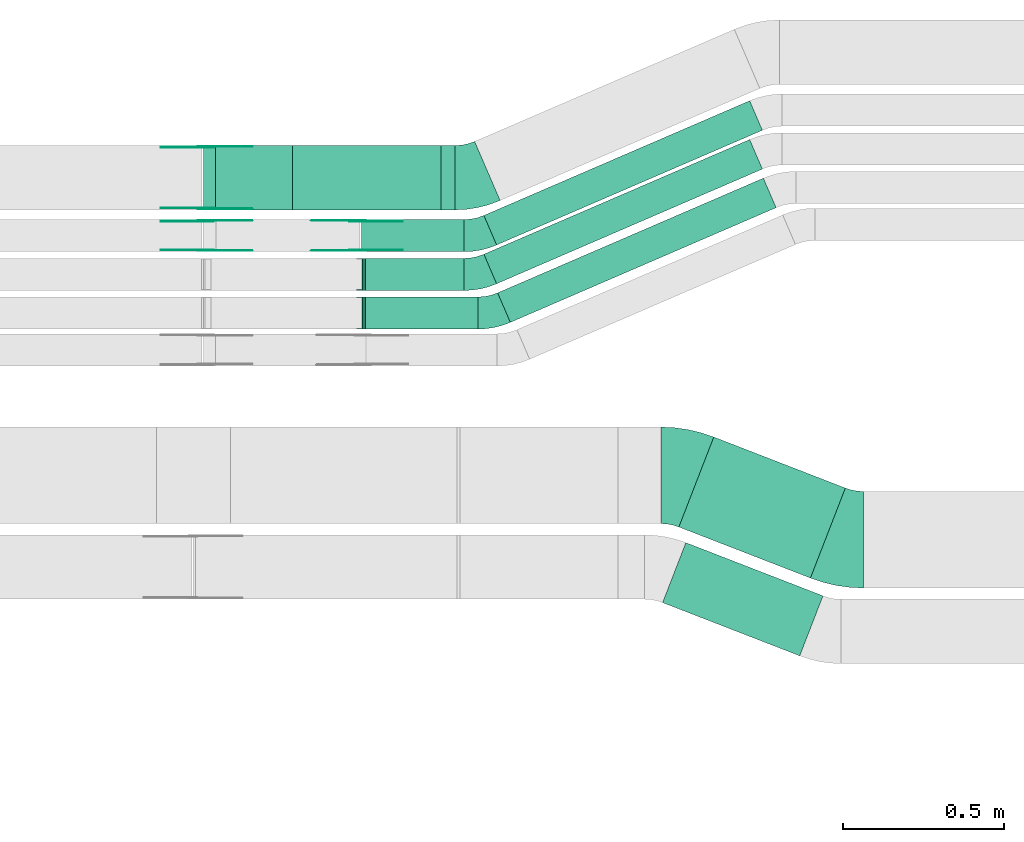
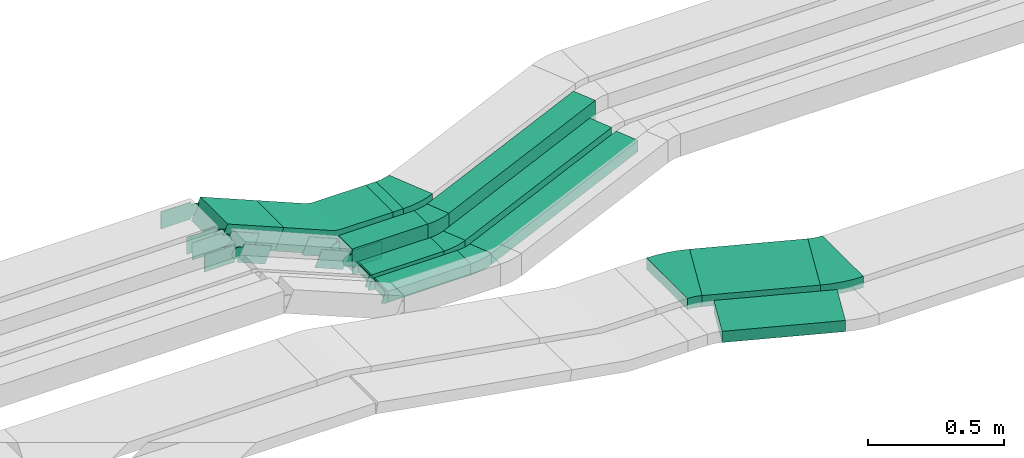
# One storey, part 17 of 31: 21 flow fittings, 10 flow segments.
"""IFC2X3 building model written with IfcOpenShell, lengths in millimetres."""

from ifc_helpers import new_model, entity, si_unit, converted_unit, derived_unit, direction, frame, frame_2d, origin, origin_2d_with_axis, place, context, subcontext, project, spatial, polyline, circle_curve, parameter, trimmed, segment, composite_curve, rectangle, outline, extrude, faceted_brep, source, transform, mapped, material, type_object, type_shapes, element, save


model = new_model("IFC2X3")

# Units and contexts
model_context = context("Model", 3, precision=0.01, world=origin(), true_north=direction((6.12303176911189e-17, 1.0)))
body_context = subcontext(model_context, "Body", "Model", "MODEL_VIEW")
ifc_project = project(units=[si_unit("LENGTHUNIT", "METRE", prefix="MILLI"), si_unit("AREAUNIT", "SQUARE_METRE"), si_unit("VOLUMEUNIT", "CUBIC_METRE"), converted_unit("PLANEANGLEUNIT", "DEGREE", entity("IfcRatioMeasure", 0.0174532925199433), si_unit("PLANEANGLEUNIT", "RADIAN"), dimensions=[0, 0, 0, 0, 0, 0, 0]), si_unit("MASSUNIT", "GRAM", prefix="KILO"), derived_unit("MASSDENSITYUNIT", [(si_unit("MASSUNIT", "GRAM", prefix="KILO"), 1), (si_unit("LENGTHUNIT", "METRE"), -3)]), derived_unit("MOMENTOFINERTIAUNIT", [(si_unit("LENGTHUNIT", "METRE"), 4)]), si_unit("TIMEUNIT", "SECOND"), si_unit("FREQUENCYUNIT", "HERTZ"), si_unit("THERMODYNAMICTEMPERATUREUNIT", "DEGREE_CELSIUS"), derived_unit("THERMALTRANSMITTANCEUNIT", [(si_unit("MASSUNIT", "GRAM", prefix="KILO"), 1), (si_unit("THERMODYNAMICTEMPERATUREUNIT", "KELVIN"), -1), (si_unit("TIMEUNIT", "SECOND"), -3)]), derived_unit("VOLUMETRICFLOWRATEUNIT", [(si_unit("LENGTHUNIT", "METRE"), 3), (si_unit("TIMEUNIT", "SECOND"), -1)]), derived_unit("MASSFLOWRATEUNIT", [(si_unit("MASSUNIT", "GRAM", prefix="KILO"), 1), (si_unit("TIMEUNIT", "SECOND"), -1)]), derived_unit("ROTATIONALFREQUENCYUNIT", [(si_unit("TIMEUNIT", "SECOND"), -1)]), si_unit("ELECTRICCURRENTUNIT", "AMPERE"), si_unit("ELECTRICVOLTAGEUNIT", "VOLT"), si_unit("POWERUNIT", "WATT"), si_unit("FORCEUNIT", "NEWTON", prefix="KILO"), si_unit("ILLUMINANCEUNIT", "LUX"), si_unit("LUMINOUSFLUXUNIT", "LUMEN"), si_unit("LUMINOUSINTENSITYUNIT", "CANDELA"), derived_unit("USERDEFINED", [(si_unit("MASSUNIT", "GRAM", prefix="KILO"), -1), (si_unit("LENGTHUNIT", "METRE"), -2), (si_unit("TIMEUNIT", "SECOND"), 3), (si_unit("LUMINOUSFLUXUNIT", "LUMEN"), 1)]), derived_unit("LINEARVELOCITYUNIT", [(si_unit("LENGTHUNIT", "METRE"), 1), (si_unit("TIMEUNIT", "SECOND"), -1)]), si_unit("PRESSUREUNIT", "PASCAL"), derived_unit("USERDEFINED", [(si_unit("LENGTHUNIT", "METRE"), -2), (si_unit("MASSUNIT", "GRAM", prefix="KILO"), 1), (si_unit("TIMEUNIT", "SECOND"), -2)]), derived_unit("LINEARFORCEUNIT", [(si_unit("MASSUNIT", "GRAM", prefix="KILO"), 1), (si_unit("LENGTHUNIT", "METRE"), 1), (si_unit("TIMEUNIT", "SECOND"), -2), (si_unit("LENGTHUNIT", "METRE"), -1)]), derived_unit("PLANARFORCEUNIT", [(si_unit("MASSUNIT", "GRAM", prefix="KILO"), 1), (si_unit("LENGTHUNIT", "METRE"), 1), (si_unit("TIMEUNIT", "SECOND"), -2), (si_unit("LENGTHUNIT", "METRE"), -2)])], contexts=[model_context])

# Site, building, storey
site_placement = place(None, frame((0.0, -0.00077364408347762, 0.0)))
site = spatial("IfcSite", under=ifc_project, at=site_placement, CompositionType="ELEMENT")
building_placement = place(site_placement, origin())
building = spatial("IfcBuilding", under=site, at=building_placement, CompositionType="ELEMENT")
storey_placement = place(building_placement, frame((0.0, 0.0, 15900.0)))
storey = spatial("IfcBuildingStorey", under=building, at=storey_placement, CompositionType="ELEMENT", Elevation=15900.0)

# Flow segments
cable_carrier_segment_type = type_object("IfcCableCarrierSegmentType", PredefinedType="CABLETRAYSEGMENT")
flow_segment_1_placement = place(storey_placement, frame((45925.0, 15609.9939089947, 2635.0)))
element("IfcFlowSegment", 1, at=flow_segment_1_placement, inside=storey, type_object=cable_carrier_segment_type, context=body_context, shape_type="SweptSolid", body=[
    extrude(rectangle(XDim=43.6419436420277, YDim=199.999999999998, at=frame_2d((-4.33075797445781e-12, 0.0), x_axis=(1.0, 0.0))), frame((21.8209718210095, 100.0, 0.0), z_axis=(0.0, 0.0, 1.0), x_axis=(-1.0, 0.0, 0.0)), (0.0, 0.0, 1.0), 99.9999999999989),
])
flow_segment_2_placement = place(storey_placement, frame((45677.8502731352, 15479.9939089947, 2635.0)))
element("IfcFlowSegment", 2, at=flow_segment_2_placement, inside=storey, type_object=cable_carrier_segment_type, context=body_context, shape_type="SweptSolid", body=[
    extrude(rectangle(XDim=319.463320328954, YDim=99.9999999999989, at=frame_2d((4.32009983342141e-12, 2.16715534406831e-12), x_axis=(1.0, 0.0))), frame((159.731660164481, 50.0, 0.0), z_axis=(0.0, 0.0, 1.0), x_axis=(-1.0, 0.0, 0.0)), (0.0, 0.0, 1.0), 100.000000000001),
])
flow_segment_3_placement = place(storey_placement, frame((45690.6793381393, 15359.4580000518, 2637.2447203761)))
element("IfcFlowSegment", 3, at=flow_segment_3_placement, inside=storey, type_object=cable_carrier_segment_type, context=body_context, shape_type="SweptSolid", body=[
    extrude(rectangle(XDim=306.634255324862, YDim=99.9999999999989, at=frame_2d((0.0, -1.08357767203415e-12), x_axis=(1.0, 0.0))), frame((153.317127662431, 50.0, 0.0), z_axis=(0.0, 0.0, 1.0), x_axis=(-1.0, 0.0, 0.0)), (0.0, 0.0, 1.0), 50.0000000000016),
])
flow_segment_4_placement = place(storey_placement, frame((45690.6793381402, 15239.4580000517, 2637.24472037608)))
element("IfcFlowSegment", 4, at=flow_segment_4_placement, inside=storey, type_object=cable_carrier_segment_type, context=body_context, shape_type="SweptSolid", body=[
    extrude(rectangle(XDim=349.299577232627, YDim=99.9999999999989, at=frame_2d((0.0, 1.08357767203415e-12), x_axis=(1.0, 0.0))), frame((174.649788616314, 50.0, 0.0)), (0.0, 0.0, 1.0), 50.0000000000016),
])
flow_segment_5_placement = place(storey_placement, frame((45186.6615770121, 15609.9939089947, 2735.0)))
element("IfcFlowSegment", 5, at=flow_segment_5_placement, inside=storey, type_object=cable_carrier_segment_type, context=body_context, shape_type="SweptSolid", body=[
    extrude(rectangle(XDim=99.9999999999999, YDim=199.999999999998, at=frame_2d((-2.00373051484348e-12, 0.0), x_axis=(1.0, 0.0))), frame((19.2307692307835, 100.0, 145.461538461525), z_axis=(0.923076923076912, 0.0, -0.384615384615411), x_axis=(0.384615384615411, 0.0, 0.923076923076912)), (0.0, 0.0, 1.0), 258.199999999951),
])
flow_segment_6_placement = place(storey_placement, frame((46664.5749166185, 14465.8684098194, 2650.0)))
element("IfcFlowSegment", 6, at=flow_segment_6_placement, inside=storey, type_object=cable_carrier_segment_type, context=body_context, shape_type="SweptSolid", body=[
    extrude(rectangle(XDim=438.486664288002, YDim=299.999999999994, at=frame_2d((3.63797880709171e-12, 2.57216470345156e-12), x_axis=(1.0, 0.0))), frame((258.65944354028, 219.157098694449, 0.0), z_axis=(0.0, 0.0, 1.0), x_axis=(-0.932264171028324, 0.361778268303765, 0.0)), (0.0, 0.0, 1.0), 50.0000000000016),
])
flow_segment_7_placement = place(storey_placement, frame((46613.9364281998, 14224.0948269223, 2650.0)))
element("IfcFlowSegment", 7, at=flow_segment_7_placement, inside=storey, type_object=cable_carrier_segment_type, context=body_context, shape_type="SweptSolid", body=[
    extrude(rectangle(XDim=457.209687450545, YDim=200.000000000007, at=frame_2d((4.03588273911737e-12, 1.57029944602982e-12), x_axis=(1.0, 0.0))), frame((249.297931958977, 175.930681591621, 0.0), z_axis=(0.0, 0.0, 1.0), x_axis=(0.932264171028315, -0.361778268303789, 0.0)), (0.0, 0.0, 1.0), 50.0000000000016),
])
flow_segment_8_placement = place(storey_placement, frame((46058.6720048741, 15500.8565107629, 2635.0)))
element("IfcFlowSegment", 8, at=flow_segment_8_placement, inside=storey, type_object=cable_carrier_segment_type, context=body_context, shape_type="SweptSolid", body=[
    extrude(rectangle(XDim=899.544928031288, YDim=100.000000000003, at=origin_2d_with_axis()), frame((432.765117043848, 224.137398231788, 0.0), z_axis=(0.0, 0.0, 1.0), x_axis=(-0.918134666973487, -0.396268511619942, 0.0)), (0.0, 0.0, 1.0), 99.9999999999989),
])
flow_segment_9_placement = place(storey_placement, frame((46058.6720048741, 15380.32060182, 2637.24472037611)))
element("IfcFlowSegment", 9, at=flow_segment_9_placement, inside=storey, type_object=cable_carrier_segment_type, context=body_context, shape_type="SweptSolid", body=[
    extrude(rectangle(XDim=899.544928031294, YDim=99.999999999988, at=frame_2d((4.54747350886464e-13, 9.80548975348938e-13), x_axis=(1.0, 0.0))), frame((432.765117043848, 224.13739823177, 0.0), z_axis=(0.0, 0.0, 1.0), x_axis=(-0.9181346669735, -0.396268511619913, 0.0)), (0.0, 0.0, 1.0), 50.0000000000016),
])
flow_segment_10_placement = place(storey_placement, frame((46101.3373267828, 15260.32060182, 2637.24472037609)))
element("IfcFlowSegment", 10, at=flow_segment_10_placement, inside=storey, type_object=cable_carrier_segment_type, context=body_context, shape_type="SweptSolid", body=[
    extrude(rectangle(XDim=899.544928031396, YDim=99.999999999988, at=frame_2d((-6.70752342557535e-12, 6.43041175862891e-12), x_axis=(1.0, 0.0))), frame((432.7651170439, 224.137398231796, 0.0), z_axis=(0.0, 0.0, 1.0), x_axis=(-0.918134666973501, -0.396268511619909, 0.0)), (0.0, 0.0, 1.0), 50.0000000000016),
])

# Flow fittings
ifc_material_1 = material(Name="G")
cable_carrier_fitting_type_1 = type_object("IfcCableCarrierFittingType", PredefinedType="NOTDEFINED", material=ifc_material_1)
shared_shape_1 = source(origin(), body_context, "Body", "SweptSolid", [
    extrude(outline(composite_curve([segment(trimmed(circle_curve(frame_2d((-41.4651162790697, 0.0), x_axis=(1.0, 0.0)), 25.0), [parameter(90.0000000000007)], [parameter(270.0)], True, "PARAMETER"), True, "CONTINUOUS"), segment(polyline([(-41.4651162790697, -25.0), (-29.9651162790697, -25.0)]), True, "CONTINUOUS"), segment(polyline([(-29.9651162790697, -25.0), (-28.1046511627907, -38.5)]), True, "CONTINUOUS"), segment(polyline([(-28.1046511627907, -38.5), (99.5348837209303, -38.5)]), True, "CONTINUOUS"), segment(polyline([(99.5348837209303, -38.5), (99.5348837209303, 38.5)]), True, "CONTINUOUS"), segment(polyline([(99.5348837209303, 38.5), (-28.1046511627907, 38.5)]), True, "CONTINUOUS"), segment(polyline([(-28.1046511627907, 38.5), (-29.9651162790697, 25.0)]), True, "CONTINUOUS"), segment(polyline([(-29.9651162790697, 25.0), (-41.46511627907, 25.0)]), True, "CONTINUOUS")], self_intersect=False)), frame((41.4651162790697, 0.0, 0.0), z_axis=(0.0, 0.0, -1.0), x_axis=(1.0, 0.0, 0.0)), (0.0, 0.0, -1.0), 2.0),
])
type_shapes(cable_carrier_fitting_type_1, [shared_shape_1])
for number, where, z_axis, x_axis in (
    (11, (45195.0, 15575.4539090049, 2885.0), (0.0, 1.0, 0.0), (0.920411299750602, 0.0, -0.390951453880668)),
    (12, (45665.8571184332, 15575.4539090049, 2685.0), (0.0, 1.0, 0.0), (-0.920411299750602, 0.0, 0.390951453880668)),
    (13, (45195.0, 15805.4539090048, 2885.0), (0.0, 1.0, 0.0), (0.92307692307691, 0.0, -0.384615384615415)),
):
    element("IfcFlowFitting", number, at=place(storey_placement, frame(where, z_axis=z_axis, x_axis=x_axis)), inside=storey, type_object=cable_carrier_fitting_type_1, material=ifc_material_1, context=body_context, shape_type="MappedRepresentation", body=[
        mapped(shared_shape_1, transform((0.0, 0.0, 0.0), scale=1.0)),
    ])
cable_carrier_fitting_type_2 = type_object("IfcCableCarrierFittingType", PredefinedType="NOTDEFINED", material=ifc_material_1)
shared_shape_2 = source(origin(), body_context, "Body", "SweptSolid", [
    extrude(outline(composite_curve([segment(trimmed(circle_curve(frame_2d((-41.4651162790697, 0.0), x_axis=(1.0, 0.0)), 25.0), [parameter(90.0000000000007)], [parameter(270.0)], True, "PARAMETER"), True, "CONTINUOUS"), segment(polyline([(-41.4651162790697, -25.0), (-29.9651162790697, -25.0)]), True, "CONTINUOUS"), segment(polyline([(-29.9651162790697, -25.0), (-28.1046511627907, -38.5)]), True, "CONTINUOUS"), segment(polyline([(-28.1046511627907, -38.5), (99.5348837209303, -38.5)]), True, "CONTINUOUS"), segment(polyline([(99.5348837209303, -38.5), (99.5348837209303, 38.5)]), True, "CONTINUOUS"), segment(polyline([(99.5348837209303, 38.5), (-28.1046511627907, 38.5)]), True, "CONTINUOUS"), segment(polyline([(-28.1046511627907, 38.5), (-29.9651162790697, 25.0)]), True, "CONTINUOUS"), segment(polyline([(-29.9651162790697, 25.0), (-41.46511627907, 25.0)]), True, "CONTINUOUS")], self_intersect=False)), frame((41.4651162790697, 0.0, 0.0)), (0.0, 0.0, 1.0), 2.0),
])
type_shapes(cable_carrier_fitting_type_2, [shared_shape_2])
for number, where, z_axis, x_axis in (
    (14, (45195.0, 15484.5339089845, 2885.0), (0.0, -1.0, 0.0), (0.920411299750602, 0.0, -0.390951453880668)),
    (15, (45665.8571184332, 15484.5339089845, 2685.0), (0.0, -1.0, 0.0), (-0.920411299750602, 0.0, 0.390951453880668)),
    (16, (45195.0, 15614.5339089845, 2885.0), (0.0, -1.0, 0.0), (0.92307692307691, 0.0, -0.384615384615415)),
):
    element("IfcFlowFitting", number, at=place(storey_placement, frame(where, z_axis=z_axis, x_axis=x_axis)), inside=storey, type_object=cable_carrier_fitting_type_2, material=ifc_material_1, context=body_context, shape_type="MappedRepresentation", body=[
        mapped(shared_shape_2, transform((0.0, 0.0, 0.0), scale=1.0)),
    ])
cable_carrier_fitting_type_3 = type_object("IfcCableCarrierFittingType", PredefinedType="NOTDEFINED", material=ifc_material_1)
shared_shape_3 = source(origin(), body_context, "Body", "SweptSolid", [
    extrude(outline(composite_curve([segment(trimmed(circle_curve(frame_2d((-41.4651162790697, 0.0), x_axis=(1.0, 0.0)), 25.0), [parameter(90.0000000000007)], [parameter(270.0)], True, "PARAMETER"), True, "CONTINUOUS"), segment(polyline([(-41.4651162790697, -25.0), (-29.9651162790697, -25.0)]), True, "CONTINUOUS"), segment(polyline([(-29.9651162790697, -25.0), (-28.1046511627907, -38.5)]), True, "CONTINUOUS"), segment(polyline([(-28.1046511627907, -38.5), (99.5348837209303, -38.5)]), True, "CONTINUOUS"), segment(polyline([(99.5348837209303, -38.5), (99.5348837209303, 38.5)]), True, "CONTINUOUS"), segment(polyline([(99.5348837209303, 38.5), (-28.1046511627907, 38.5)]), True, "CONTINUOUS"), segment(polyline([(-28.1046511627907, 38.5), (-29.9651162790697, 25.0)]), True, "CONTINUOUS"), segment(polyline([(-29.9651162790697, 25.0), (-41.46511627907, 25.0)]), True, "CONTINUOUS")], self_intersect=False)), frame((41.4651162790697, 0.0, 0.0), z_axis=(0.0, 0.0, -1.0), x_axis=(1.0, 0.0, 0.0)), (0.0, 0.0, -1.0), 2.0),
])
type_shapes(cable_carrier_fitting_type_3, [shared_shape_3])
for number, where, z_axis, x_axis in (
    (17, (45195.0, 15486.5339089845, 2885.0), (0.0, -1.0, 0.0), (-1.0, 0.0, 0.0)),
    (18, (45665.8571184332, 15486.5339089845, 2685.0), (0.0, -1.0, 0.0), (1.0, 0.0, 0.0)),
    (19, (45195.0, 15616.5339089845, 2885.0), (0.0, -1.0, 0.0), (-1.0, 0.0, 0.0)),
):
    element("IfcFlowFitting", number, at=place(storey_placement, frame(where, z_axis=z_axis, x_axis=x_axis)), inside=storey, type_object=cable_carrier_fitting_type_3, material=ifc_material_1, context=body_context, shape_type="MappedRepresentation", body=[
        mapped(shared_shape_3, transform((0.0, 0.0, 0.0), scale=1.0)),
    ])
cable_carrier_fitting_type_4 = type_object("IfcCableCarrierFittingType", PredefinedType="NOTDEFINED", material=ifc_material_1)
shared_shape_4 = source(origin(), body_context, "Body", "SweptSolid", [
    extrude(outline(composite_curve([segment(trimmed(circle_curve(frame_2d((-41.4651162790697, 0.0), x_axis=(1.0, 0.0)), 25.0), [parameter(90.0000000000007)], [parameter(270.0)], True, "PARAMETER"), True, "CONTINUOUS"), segment(polyline([(-41.4651162790697, -25.0), (-29.9651162790697, -25.0)]), True, "CONTINUOUS"), segment(polyline([(-29.9651162790697, -25.0), (-28.1046511627907, -38.5)]), True, "CONTINUOUS"), segment(polyline([(-28.1046511627907, -38.5), (99.5348837209303, -38.5)]), True, "CONTINUOUS"), segment(polyline([(99.5348837209303, -38.5), (99.5348837209303, 38.5)]), True, "CONTINUOUS"), segment(polyline([(99.5348837209303, 38.5), (-28.1046511627907, 38.5)]), True, "CONTINUOUS"), segment(polyline([(-28.1046511627907, 38.5), (-29.9651162790697, 25.0)]), True, "CONTINUOUS"), segment(polyline([(-29.9651162790697, 25.0), (-41.46511627907, 25.0)]), True, "CONTINUOUS")], self_intersect=False)), frame((41.4651162790697, 0.0, 0.0)), (0.0, 0.0, 1.0), 2.0),
])
type_shapes(cable_carrier_fitting_type_4, [shared_shape_4])
for number, where, z_axis, x_axis in (
    (20, (45195.0, 15573.4539090049, 2885.0), (0.0, 1.0, 0.0), (-1.0, 0.0, 0.0)),
    (21, (45665.8571184332, 15573.4539090049, 2685.0), (0.0, 1.0, 0.0), (1.0, 0.0, 0.0)),
    (22, (45195.0, 15803.4539090048, 2885.0), (0.0, 1.0, 0.0), (-1.0, 0.0, 0.0)),
):
    element("IfcFlowFitting", number, at=place(storey_placement, frame(where, z_axis=z_axis, x_axis=x_axis)), inside=storey, type_object=cable_carrier_fitting_type_4, material=ifc_material_1, context=body_context, shape_type="MappedRepresentation", body=[
        mapped(shared_shape_4, transform((0.0, 0.0, 0.0), scale=1.0)),
    ])
ifc_material_2 = material()
cable_carrier_fitting_type_5 = type_object("IfcCableCarrierFittingType", PredefinedType="NOTDEFINED", material=ifc_material_2)
shared_shape_5 = source(origin(), body_context, "Body", "Brep", [
    faceted_brep([(-9.86154249456779, 25.0, 50.0), (-9.86154249456779, 25.0, -50.0), (-9.86154249456795, -25.0, -50.0), (-9.86154249456795, -25.0, -47.4600000101565), (-9.8615424945678, 22.46000001016, -47.4600000101565), (-9.8615424945678, 22.46000001016, 47.4600000101635), (-9.86154249456795, -25.0, 47.4600000101635), (-9.86154249456795, -25.0, 50.0), (-0.369250245826843, 26.8721728676359, 50.0), (18.6153342516549, -19.3834813970913, 50.0), (18.6153342516549, -19.3834813970913, 47.4600000101635), (0.595166642787549, 24.522385640387, 47.4600000101635), (0.595166642787553, 24.522385640387, -47.4600000101565), (18.6153342516549, -19.3834813970913, -47.4600000101565), (18.6153342516549, -19.3834813970913, -50.0), (-0.369250245826849, 26.8721728676359, -50.0), (-4.93077124728357, 25.0, 50.0), (-4.93077124728367, 25.0, -50.0), (4.93077124728457, -25.0, -50.0), (4.93077124728457, -25.0, -47.4600000101565), (-4.42980489056346, 22.46000001016, -47.4600000101565), (-4.42980489056346, 22.46000001016, 47.4600000101635), (4.93077124728457, -25.0, 47.4600000101635), (4.93077124728457, -25.0, 50.0)], [[[0, 1, 2, 3, 4, 5, 6, 7]], [[8, 9, 10, 11, 12, 13, 14, 15]], [[1, 0, 16, 17]], [[2, 1, 17, 15, 14, 18]], [[3, 2, 18, 19]], [[4, 3, 19, 13, 12, 20]], [[5, 4, 20, 21]], [[6, 5, 21, 11, 10, 22]], [[7, 6, 22, 23]], [[0, 7, 23, 9, 8, 16]], [[17, 16, 8, 15]], [[19, 18, 14, 13]], [[21, 20, 12, 11]], [[23, 22, 10, 9]]]),
])
type_shapes(cable_carrier_fitting_type_5, [shared_shape_5])
for number, where, z_axis, x_axis in (
    (23, (45680.8177956447, 15409.4580000518, 2662.24472037612), (0.0, 1.0, 0.0), (-1.0, 0.0, 0.0)),
    (24, (45680.8177956456, 15289.4580000518, 2662.24472037611), (0.0, -1.0, 0.0), (0.925113085294543, 0.0, -0.379691689949639)),
):
    element("IfcFlowFitting", number, at=place(storey_placement, frame(where, z_axis=z_axis, x_axis=x_axis)), inside=storey, type_object=cable_carrier_fitting_type_5, material=ifc_material_2, context=body_context, shape_type="MappedRepresentation", body=[
        mapped(shared_shape_5, transform((0.0, 0.0, 0.0), scale=1.0)),
    ])
cable_carrier_fitting_type_6 = type_object("IfcCableCarrierFittingType", Name="470_DKC_S5_CS 90 internal vertical angle:-", PredefinedType="NOTDEFINED", material=ifc_material_2)
shared_shape_6 = source(origin(), body_context, "Body", "SweptSolid", [
    extrude(outline(composite_curve([segment(polyline([(-244.557692307692, -77.2115384615417), (-27.5576923076944, -77.2115384615417)]), True, "CONTINUOUS"), segment(trimmed(circle_curve(frame_2d((-27.5576923076947, 137.788461538457), x_axis=(0.0, -1.0)), 214.999999999999), [parameter(0.0)], [parameter(22.6198649480428)], True, "PARAMETER"), True, "CONTINUOUS"), segment(polyline([(55.134615384621, -60.6730769230767), (255.442307692308, 22.788461538469)]), True, "CONTINUOUS"), segment(polyline([(255.442307692308, 22.7884615384689), (216.980769230765, 115.09615384616)]), True, "CONTINUOUS"), segment(polyline([(216.980769230765, 115.09615384616), (16.6730769230785, 31.6346153846142)]), True, "CONTINUOUS"), segment(trimmed(circle_curve(frame_2d((-27.5576923076947, 137.788461538457), x_axis=(0.0, -1.0)), 114.999999999999), [parameter(0.0)], [parameter(22.6198649480428)], True, "PARAMETER"), False, "CONTINUOUS"), segment(polyline([(-27.5576923076944, 22.7884615384585), (-244.557692307692, 22.7884615384586)]), True, "CONTINUOUS"), segment(polyline([(-244.557692307692, 22.7884615384586), (-244.557692307692, -77.2115384615417)]), True, "CONTINUOUS")], self_intersect=False)), frame((-5.44230769230004, 27.2115384615344, -100.0)), (0.0, 0.0, 1.0), 200.0),
])
type_shapes(cable_carrier_fitting_type_6, [shared_shape_6])
flow_fitting_1_placement = place(storey_placement, frame((45675.0, 15709.9939089947, 2685.0), z_axis=(0.0, 1.0, 0.0), x_axis=(-1.0, 0.0, 0.0)))
element("IfcFlowFitting", 25, at=flow_fitting_1_placement, inside=storey, type_object=cable_carrier_fitting_type_6, material=ifc_material_2, Name="470_DKC_S5_CS 90 internal vertical angle:-", ObjectType="470_DKC_S5_CS 90 internal vertical angle:-", context=body_context, shape_type="MappedRepresentation", body=[
    mapped(shared_shape_6, transform((0.0, 0.0, 0.0), scale=1.0)),
])
cable_carrier_fitting_type_7 = type_object("IfcCableCarrierFittingType", Name="470_DKC_S5_Variable Angle Elbow 0-45:-", PredefinedType="NOTDEFINED", material=ifc_material_2)
shared_shape_7 = source(origin(), body_context, "Body", "SweptSolid", [
    extrude(outline(composite_curve([segment(polyline([(-55.2498062883172, -160.250818912827), (-54.2498062883156, -160.250818912827)]), True, "CONTINUOUS"), segment(trimmed(circle_curve(frame_2d((-54.249806288324, 289.749181087173), x_axis=(0.0, -1.0)), 450.0), [parameter(0.0)], [parameter(21.2094457966376)], True, "PARAMETER"), True, "CONTINUOUS"), segment(polyline([(108.550414448369, -129.769695875574), (109.482678619397, -129.40791760727)]), True, "CONTINUOUS"), segment(polyline([(109.482678619397, -129.40791760727), (0.949198128268728, 150.271333701228)]), True, "CONTINUOUS"), segment(polyline([(0.94919812826872, 150.271333701228), (0.0169339572402172, 149.909555432924)]), True, "CONTINUOUS"), segment(trimmed(circle_curve(frame_2d((-54.249806288324, 289.749181087173), x_axis=(0.0, -1.0)), 150.0), [parameter(0.0)], [parameter(21.2094457966376)], True, "PARAMETER"), False, "CONTINUOUS"), segment(polyline([(-54.2498062883207, 139.749181087173), (-55.2498062883223, 139.749181087173)]), True, "CONTINUOUS"), segment(polyline([(-55.2498062883223, 139.749181087173), (-55.2498062883172, -160.250818912827)]), True, "CONTINUOUS")], self_intersect=False)), frame((-1.91926319939191, 10.2508189128181, -25.0)), (0.0, 0.0, 1.0), 49.9999999999992),
])
type_shapes(cable_carrier_fitting_type_7, [shared_shape_7])
for number, where, z_axis, x_axis, name in (
    (26, (47180.9237386279, 14585.0255085139, 2675.0), (0.0, 0.0, 1.0), (0.932264171028328, -0.361778268303755, 0.0), "470_DKC_S5_Variable Angle Elbow 0-45:-"),
    (27, (46665.5449816896, 14785.0255085139, 2675.0), (0.0, 0.0, 1.0), (-0.932264171028324, 0.361778268303765, 0.0), "470_DKC_S5_Variable Angle Elbow 0-45:-"),
):
    element("IfcFlowFitting", number, at=place(storey_placement, frame(where, z_axis=z_axis, x_axis=x_axis)), inside=storey, type_object=cable_carrier_fitting_type_7, material=ifc_material_2, Name=name, ObjectType="470_DKC_S5_Variable Angle Elbow 0-45:-", context=body_context, shape_type="MappedRepresentation", body=[
        mapped(shared_shape_7, transform((0.0, 0.0, 0.0), scale=1.0)),
    ])
cable_carrier_fitting_type_8 = type_object("IfcCableCarrierFittingType", Name="470_DKC_S5_Variable Angle Elbow 0-45:-", PredefinedType="NOTDEFINED", material=ifc_material_2)
shared_shape_8 = source(origin(), body_context, "Body", "SweptSolid", [
    extrude(outline(composite_curve([segment(polyline([(-50.5130976192309, -110.332233756216), (-49.5130976192295, -110.332233756216)]), True, "CONTINUOUS"), segment(trimmed(circle_curve(frame_2d((-49.51309761923, 239.667766243783), x_axis=(0.0, -1.0)), 350.0), [parameter(0.0)], [parameter(23.3451113937058)], True, "PARAMETER"), True, "CONTINUOUS"), segment(polyline([(89.1808814477325, -81.6793671969443), (90.0990161147059, -81.2830986853244)]), True, "CONTINUOUS"), segment(polyline([(90.0990161147059, -81.2830986853245), (10.8453137907275, 102.343834709377)]), True, "CONTINUOUS"), segment(polyline([(10.8453137907275, 102.343834709377), (9.92717912375383, 101.947566197757)]), True, "CONTINUOUS"), segment(trimmed(circle_curve(frame_2d((-49.51309761923, 239.667766243783), x_axis=(0.0, -1.0)), 150.0), [parameter(0.0)], [parameter(23.3451113937058)], True, "PARAMETER"), False, "CONTINUOUS"), segment(polyline([(-49.5130976192295, 89.6677662437834), (-50.5130976192309, 89.6677662437834)]), True, "CONTINUOUS"), segment(polyline([(-50.5130976192309, 89.6677662437834), (-50.5130976192309, -110.332233756216)]), True, "CONTINUOUS")], self_intersect=False)), frame((-2.13454193950104, 10.3322337562084, -50.0)), (0.0, 0.0, 1.0), 100.0),
])
type_shapes(cable_carrier_fitting_type_8, [shared_shape_8])
flow_fitting_2_placement = place(storey_placement, frame((46021.2896217513, 15709.9939089947, 2685.0)))
element("IfcFlowFitting", 28, at=flow_fitting_2_placement, inside=storey, type_object=cable_carrier_fitting_type_8, material=ifc_material_2, Name="470_DKC_S5_Variable Angle Elbow 0-45:-", ObjectType="470_DKC_S5_Variable Angle Elbow 0-45:-", context=body_context, shape_type="MappedRepresentation", body=[
    mapped(shared_shape_8, transform((0.0, 0.0, 0.0), scale=1.0)),
])
cable_carrier_fitting_type_9 = type_object("IfcCableCarrierFittingType", Name="470_DKC_S5_Variable Angle Elbow 0-45:-", PredefinedType="NOTDEFINED", material=ifc_material_2)
shared_shape_9 = source(origin(), body_context, "Body", "SweptSolid", [
    extrude(outline(composite_curve([segment(polyline([(-40.6063848287355, -58.2856004305556), (-39.6063848287342, -58.2856004305556)]), True, "CONTINUOUS"), segment(trimmed(circle_curve(frame_2d((-39.6063848287368, 191.714399569444), x_axis=(0.0, -1.0)), 250.0), [parameter(0.0)], [parameter(23.3451113937074)], True, "PARAMETER"), True, "CONTINUOUS"), segment(polyline([(59.4607430762446, -37.8192671739291), (60.378877743218, -37.4229986623092)]), True, "CONTINUOUS"), segment(polyline([(60.378877743218, -37.4229986623092), (20.7520265812255, 54.3904680350402)]), True, "CONTINUOUS"), segment(polyline([(20.7520265812256, 54.3904680350402), (19.833891914252, 53.9941995234202)]), True, "CONTINUOUS"), segment(trimmed(circle_curve(frame_2d((-39.6063848287368, 191.714399569444), x_axis=(0.0, -1.0)), 150.0), [parameter(0.0)], [parameter(23.3451113937074)], True, "PARAMETER"), False, "CONTINUOUS"), segment(polyline([(-39.6063848287351, 41.7143995694443), (-40.6063848287364, 41.7143995694443)]), True, "CONTINUOUS"), segment(polyline([(-40.6063848287364, 41.7143995694443), (-40.6063848287355, -58.2856004305556)]), True, "CONTINUOUS")], self_intersect=False)), frame((-1.7117268182506, 8.28560043054716, -50.0)), (0.0, 0.0, 1.0), 100.0),
])
type_shapes(cable_carrier_fitting_type_9, [shared_shape_9])
flow_fitting_3_placement = place(storey_placement, frame((46039.6317051111, 15529.9939089947, 2685.0)))
element("IfcFlowFitting", 29, at=flow_fitting_3_placement, inside=storey, type_object=cable_carrier_fitting_type_9, material=ifc_material_2, Name="470_DKC_S5_Variable Angle Elbow 0-45:-", ObjectType="470_DKC_S5_Variable Angle Elbow 0-45:-", context=body_context, shape_type="MappedRepresentation", body=[
    mapped(shared_shape_9, transform((0.0, 0.0, 0.0), scale=1.0)),
])
cable_carrier_fitting_type_10 = type_object("IfcCableCarrierFittingType", Name="470_DKC_S5_Variable Angle Elbow 0-45:-", PredefinedType="NOTDEFINED", material=ifc_material_2)
shared_shape_10 = source(origin(), body_context, "Body", "SweptSolid", [
    extrude(outline(composite_curve([segment(polyline([(-40.6063848287359, -58.2856004305552), (-39.6063848287346, -58.2856004305552)]), True, "CONTINUOUS"), segment(trimmed(circle_curve(frame_2d((-39.606384828735, 191.714399569444), x_axis=(0.0, -1.0)), 250.0), [parameter(0.0)], [parameter(23.3451113937073)], True, "PARAMETER"), True, "CONTINUOUS"), segment(polyline([(59.460743076244, -37.8192671739297), (60.3788777432174, -37.4229986623098)]), True, "CONTINUOUS"), segment(polyline([(60.3788777432174, -37.4229986623098), (20.7520265812259, 54.39046803504)]), True, "CONTINUOUS"), segment(polyline([(20.752026581226, 54.39046803504), (19.8338919142524, 53.99419952342)]), True, "CONTINUOUS"), segment(trimmed(circle_curve(frame_2d((-39.606384828735, 191.714399569444), x_axis=(0.0, -1.0)), 150.0), [parameter(0.0)], [parameter(23.3451113937073)], True, "PARAMETER"), False, "CONTINUOUS"), segment(polyline([(-39.6063848287346, 41.7143995694447), (-40.6063848287359, 41.7143995694447)]), True, "CONTINUOUS"), segment(polyline([(-40.6063848287359, 41.7143995694447), (-40.6063848287359, -58.2856004305552)]), True, "CONTINUOUS")], self_intersect=False)), frame((-1.7117268182506, 8.28560043054711, -25.0)), (0.0, 0.0, 1.0), 50.0000000000001),
])
type_shapes(cable_carrier_fitting_type_10, [shared_shape_10])
for number, where, name in (
    (30, (46039.6317051111, 15409.4580000518, 2662.24472037611), "470_DKC_S5_Variable Angle Elbow 0-45:-"),
    (31, (46082.2970270198, 15289.4580000518, 2662.24472037609), "470_DKC_S5_Variable Angle Elbow 0-45:-"),
):
    element("IfcFlowFitting", number, at=place(storey_placement, frame(where)), inside=storey, type_object=cable_carrier_fitting_type_10, material=ifc_material_2, Name=name, ObjectType="470_DKC_S5_Variable Angle Elbow 0-45:-", context=body_context, shape_type="MappedRepresentation", body=[
        mapped(shared_shape_10, transform((0.0, 0.0, 0.0), scale=1.0)),
    ])

save(model, "model.ifc")
